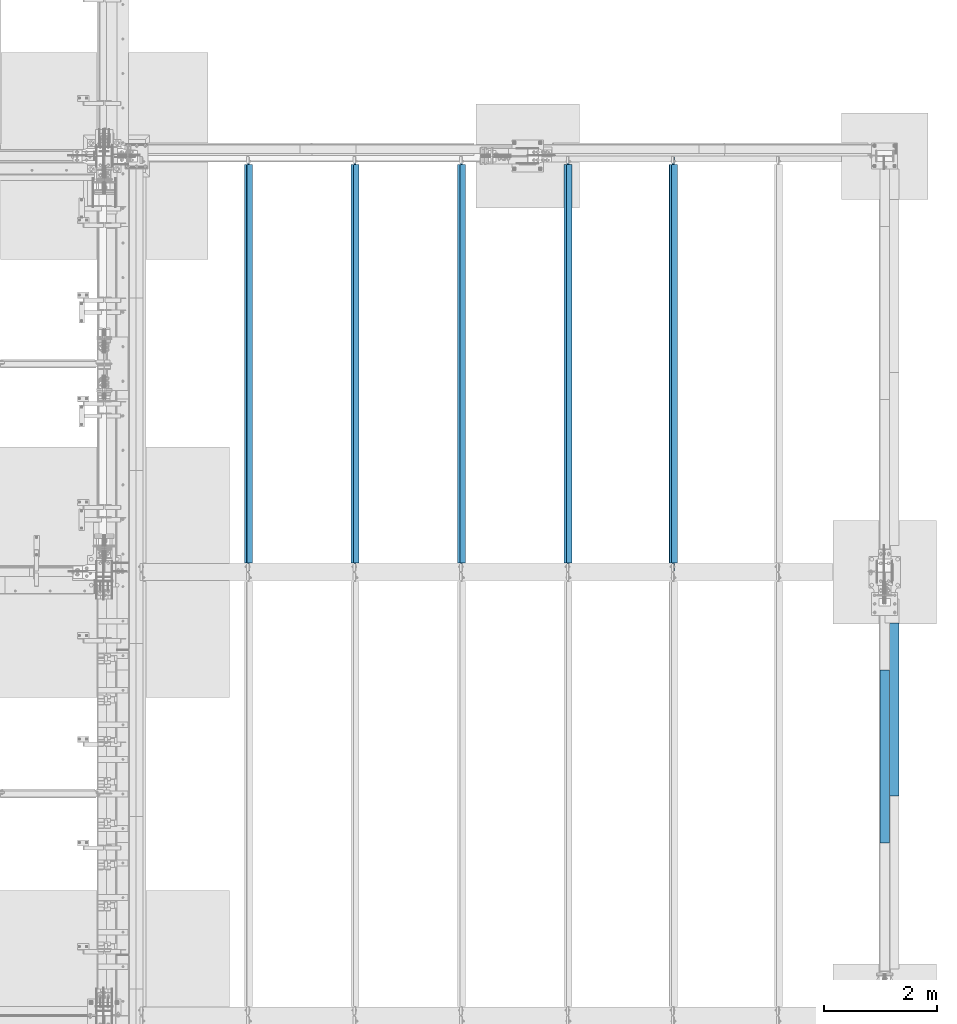
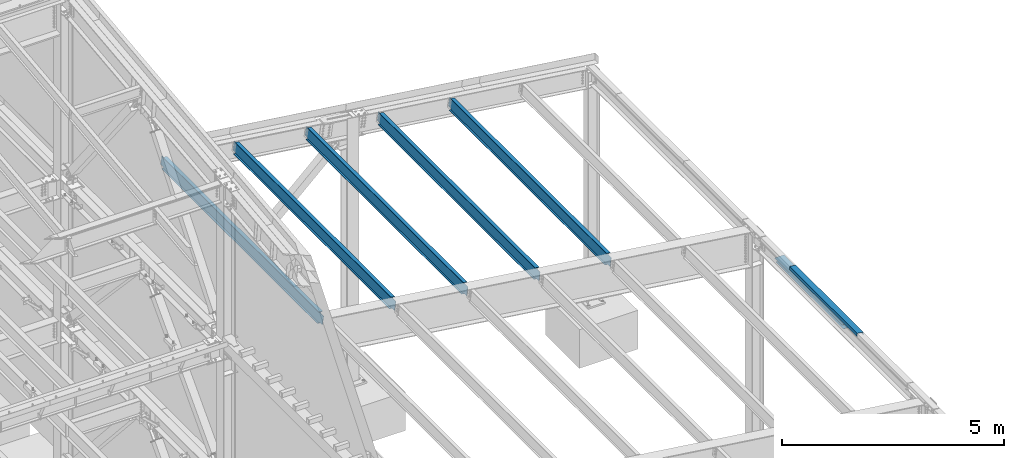
# One storey, part 751 of 1179: 7 beams, 6 elements without a shape of their own.
"""IFC2X3 building model written with IfcOpenShell, lengths in millimetres."""

from ifc_helpers import new_model, si_unit, frame, origin_with_axes, place, context, subcontext, project, spatial, faceted_brep, material, type_object, element, aggregate, save


model = new_model("IFC2X3")

# Units and contexts
model_context = context("Model", 3, precision=1e-05, world=origin_with_axes())
body_context = subcontext(model_context, "Body", "Model", "MODEL_VIEW")
ifc_project = project(units=[si_unit("LENGTHUNIT", "METRE", prefix="MILLI"), si_unit("AREAUNIT", "SQUARE_METRE"), si_unit("VOLUMEUNIT", "CUBIC_METRE"), si_unit("MASSUNIT", "GRAM", prefix="KILO"), si_unit("TIMEUNIT", "SECOND"), si_unit("PLANEANGLEUNIT", "RADIAN"), si_unit("SOLIDANGLEUNIT", "STERADIAN"), si_unit("THERMODYNAMICTEMPERATUREUNIT", "DEGREE_CELSIUS"), si_unit("LUMINOUSINTENSITYUNIT", "LUMEN")], contexts=[model_context])

# Site, building, storey
site_placement = place(None, origin_with_axes())
site = spatial("IfcSite", under=ifc_project, at=site_placement, CompositionType="ELEMENT")
building_placement = place(site_placement, origin_with_axes())
building = spatial("IfcBuilding", under=site, at=building_placement, Name="Undefined", CompositionType="ELEMENT")
storey_placement = place(building_placement, origin_with_axes())
storey = spatial("IfcBuildingStorey", under=building, at=storey_placement, Name="Undefined", CompositionType="ELEMENT", Elevation=0.0)

# Assembly, beams
assembly_1_placement = place(storey_placement, origin_with_axes())
assembly_1 = element("IfcElementAssembly", 1, at=assembly_1_placement, inside=storey, Name="BEAM", AssemblyPlace="NOTDEFINED", PredefinedType="RIGID_FRAME")
ifc_material_1 = material(Name="STEEL/A36")
beam_type_1 = type_object("IfcBeamType", PredefinedType="NOTDEFINED")
beam_1_placement = place(assembly_1_placement, frame((37996.8124994166, 23800.6191790178, 6096.00000000004), z_axis=(0.0, -1.0, 0.0), x_axis=(0.0, 0.0, 1.0)))
beam_1 = element("IfcBeam", 2, at=beam_1_placement, type_object=beam_type_1, material=ifc_material_1, Name="BENT_PLATE", context=body_context, shape_type="Brep", body=[
    faceted_brep([(-2.91038304567337e-11, -4.76250000000073, -1524.0), (-2.91038304567337e-11, -4.76250000000073, 1524.0), (2.91038304567337e-11, 4.76250000000073, 1524.0), (2.91038304567337e-11, 4.76250000000073, -1524.0), (92.8848876952779, 4.76250000074651, 1524.0), (92.8848876952779, 4.76250000074651, -1524.0), (81.9873102930469, -4.76249999933498, -1524.0), (81.9873102930469, -4.76249999933498, 1524.0), (70.5918350219381, -160.337506103519, 1524.0), (70.5918350219381, -160.337506103519, -1524.0), (62.266532833075, -150.812506103524, -1524.0), (62.266532833075, -150.812506103524, 1524.0), (-7.6397554948926e-11, -160.337506103519, 1524.0), (-7.6397554948926e-11, -160.337506103519, -1524.0), (8.54161044117063e-08, -150.812499999749, 1524.0), (8.54161044117063e-08, -150.812499999749, -1524.0)], [[[0, 1, 2, 3]], [[3, 2, 4, 5]], [[1, 0, 6, 7]], [[5, 4, 8, 9]], [[7, 6, 10, 11]], [[9, 8, 12, 13]], [[8, 4, 2, 1, 7, 11, 14, 12]], [[11, 10, 15, 14]], [[10, 6, 0, 3, 5, 9, 13, 15]], [[14, 15, 13, 12]]]),
])
beam_type_2 = type_object("IfcBeamType", PredefinedType="NOTDEFINED")
beam_2_placement = place(assembly_1_placement, frame((38113.49375, 24627.5611179414, 5764.21250000249), z_axis=(0.0, 1.0, 0.0), x_axis=(1.0, 0.0, 0.0)))
beam_2 = element("IfcBeam", 3, at=beam_2_placement, type_object=beam_type_2, material=ifc_material_1, Name="BENT_PLATE", context=body_context, shape_type="Brep", body=[
    faceted_brep([(0.0, -3.17499999999927, -1524.0), (6.00266503170133e-10, -3.17499999922438, 1524.00000000052), (6.00266503170133e-10, 3.17500000077416, 1524.00000000052), (0.0, 3.17499999999927, -1524.0), (215.900000000009, 3.17500000000018, 1524.0), (215.900000000009, 3.17500000000018, -1524.0), (209.550000000003, -3.17500000000018, -1524.0), (209.550000000003, -3.17500000000018, 1524.0), (215.900000000009, -123.825, 1524.0), (215.900000000009, -123.825, -1524.0), (209.550000000003, -117.474999999999, -1524.0), (209.550000000003, -117.474999999999, 1524.0), (-34.1312499999985, -123.825, 1524.0), (-34.1312499999985, -123.825, -1524.0), (-34.1312499999985, -117.474999999999, 1524.0), (-34.1312499999985, -117.474999999999, -1524.0)], [[[0, 1, 2, 3]], [[3, 2, 4, 5]], [[1, 0, 6, 7]], [[5, 4, 8, 9]], [[7, 6, 10, 11]], [[9, 8, 12, 13]], [[8, 4, 2, 1, 7, 11, 14, 12]], [[11, 10, 15, 14]], [[10, 6, 0, 3, 5, 9, 13, 15]], [[14, 15, 13, 12]]]),
])
aggregate(assembly_1, [beam_2, beam_1])

# Assembly, beam
assembly_2_placement = place(storey_placement, origin_with_axes())
assembly_2 = element("IfcElementAssembly", 4, at=assembly_2_placement, inside=storey, Name="BEAM", AssemblyPlace="NOTDEFINED", PredefinedType="RIGID_FRAME")
ifc_material_2 = material(Name="STEEL/A992")
beam_type_3 = type_object("IfcBeamType", Name="W12X22", PredefinedType="NOTDEFINED")
beam_3_placement = place(assembly_2_placement, frame((34345.3820076777, 27051.0, 6524.29881454697), z_axis=(0.133813223953133, 0.0, 0.991006569652931), x_axis=(0.0, 1.0, 0.0)))
beam_3 = element("IfcBeam", 5, at=beam_3_placement, type_object=beam_type_3, material=ifc_material_2, Name="BEAM", ObjectType="W12X22", context=body_context, shape_type="Brep", body=[
    faceted_brep([(7194.54999999999, -3.17499999982101, -144.462500000049), (7194.54999999999, -50.7999999998428, -144.462500000063), (7194.54999999999, -50.7999999998283, -155.575000000066), (7194.54999999999, 50.8000000001994, -155.575000000039), (7194.54999999999, 50.8000000001775, -144.462500000034), (7194.54999999999, 3.17500000017026, -144.462500000049), (7194.54999999999, 3.17500000015571, -136.524999807967), (7194.54999999999, -3.17499999984284, -136.524999807963), (7195.51672992258, 3.17500000016298, -131.664920289917), (7195.51672992258, -3.17499999984284, -131.664920289913), (7198.26974382306, 3.17500000015571, -127.54474382176), (7198.26974382306, -3.17499999985012, -127.544743821756), (7202.38992029121, 3.17500000014843, -124.791729921279), (7202.38992029121, -3.17499999985012, -124.791729921275), (7207.24999980926, 3.17500000014115, -123.824999998687), (7207.24999980926, -3.17499999985012, -123.824999998684), (7321.54999999999, -3.17499999985012, -123.82499999858), (7321.54999999999, 3.17500000014843, -123.824999998573), (161.925000000007, 3.17499999983556, 144.462500000051), (161.925000000007, 50.7999999998428, 144.462500000063), (7194.54999999999, 50.7999999998428, 144.462500000063), (7194.54999999999, 3.17499999983556, 144.462500000051), (161.925000000007, -3.17499999984284, -136.524999799629), (161.925000000007, 3.17500000016298, -136.524999799632), (161.925000000007, 3.17500000017026, -144.462500000049), (161.925000000007, 50.8000000001775, -144.462500000034), (161.925000000007, 50.8000000001994, -155.575000000039), (161.925000000007, -50.7999999998283, -155.575000000066), (161.925000000007, -50.7999999998428, -144.462500000063), (161.925000000007, -3.17499999982101, -144.462500000049), (160.958270077419, -3.17499999984284, -131.664920281577), (160.958270077419, 3.17500000015571, -131.664920281581), (158.205256176941, -3.17499999984284, -127.54474381342), (158.205256176941, 3.17500000014843, -127.544743813425), (154.085079708788, -3.17499999985012, -124.791729912939), (154.085079708788, 3.17500000015571, -124.791729912944), (149.225000190741, -3.17499999985012, -123.824999990349), (149.225000190741, 3.17500000014115, -123.824999990355), (20.6375000000044, -3.17499999985739, -123.824999990466), (20.6375000000044, 3.17500000014843, -123.824999990458), (20.6375000000044, -3.17500000014115, 117.475000009781), (20.6375000000044, 3.17499999986467, 117.475000009788), (149.225000190741, -3.17500000014115, 117.475000009897), (149.225000190741, 3.17499999986467, 117.475000009894), (154.085079708788, -3.17500000014115, 118.441729932485), (154.085079708788, 3.17499999986467, 118.441729932481), (158.205256176941, -3.17500000014843, 121.194743832966), (158.205256176941, 3.17499999985739, 121.194743832963), (160.958270077419, -3.17500000014843, 125.314920301123), (160.958270077419, 3.17499999985739, 125.31492030112), (161.925000000007, -3.17500000014843, 130.174999819174), (161.925000000007, 3.17499999985012, 130.17499981917), (161.925000000007, -50.8000000001994, 155.575000000041), (161.925000000007, 50.7999999998356, 155.575000000066), (161.925000000007, -3.17500000017026, 144.462500000049), (161.925000000007, -50.8000000001775, 144.462500000034), (7194.54999999999, -3.17500000017026, 144.462500000049), (7194.54999999999, -50.8000000001775, 144.462500000034), (7194.54999999999, -50.8000000001994, 155.575000000041), (7194.54999999999, 50.7999999998356, 155.575000000066), (7194.54999999999, -3.17500000014843, 130.174999810839), (7194.54999999999, 3.17499999984284, 130.174999810835), (7195.51672992258, -3.17500000014843, 125.314920292787), (7195.51672992258, 3.17499999985739, 125.314920292783), (7198.26974382306, -3.17500000014843, 121.19474382463), (7198.26974382306, 3.17499999985739, 121.194743824626), (7202.38992029121, -3.17500000014115, 118.441729924149), (7202.38992029121, 3.17499999985739, 118.441729924147), (7207.24999980926, -3.17500000014115, 117.475000001559), (7207.24999980926, 3.17499999985739, 117.475000001556), (7321.54999999999, -3.17500000014115, 117.475000001665), (7321.54999999999, 3.17499999985739, 117.475000001672)], [[[0, 1, 2, 3, 4, 5, 6, 7]], [[7, 6, 8, 9]], [[9, 8, 10, 11]], [[11, 10, 12, 13]], [[13, 12, 14, 15]], [[16, 15, 14, 17]], [[18, 19, 20, 21]], [[22, 23, 24, 25, 26, 27, 28, 29]], [[30, 31, 23, 22]], [[32, 33, 31, 30]], [[34, 35, 33, 32]], [[36, 37, 35, 34]], [[38, 39, 37, 36]], [[40, 41, 39, 38]], [[42, 43, 41, 40]], [[44, 45, 43, 42]], [[46, 47, 45, 44]], [[48, 49, 47, 46]], [[50, 51, 49, 48]], [[52, 53, 19, 18, 51, 50, 54, 55]], [[55, 54, 56, 57]], [[52, 55, 57, 58]], [[53, 52, 58, 59]], [[19, 53, 59, 20]], [[58, 57, 56, 60, 61, 21, 20, 59]], [[62, 63, 61, 60]], [[64, 65, 63, 62]], [[66, 67, 65, 64]], [[68, 69, 67, 66]], [[70, 71, 69, 68]], [[71, 70, 16, 17]], [[12, 10, 8, 6, 5, 24, 23, 31, 33, 35, 37, 39, 41, 43, 45, 47, 49, 51, 18, 21, 61, 63, 65, 67, 69, 71, 17, 14]], [[25, 24, 5, 4]], [[26, 25, 4, 3]], [[27, 26, 3, 2]], [[28, 27, 2, 1]], [[29, 28, 1, 0]], [[70, 68, 66, 64, 62, 60, 56, 54, 50, 48, 46, 44, 42, 40, 38, 36, 34, 32, 30, 22, 29, 0, 7, 9, 11, 13, 15, 16]]]),
])
aggregate(assembly_2, [beam_3])

assembly_3_placement = place(storey_placement, origin_with_axes())
assembly_3 = element("IfcElementAssembly", 6, at=assembly_3_placement, inside=storey, Name="BEAM", AssemblyPlace="NOTDEFINED", PredefinedType="RIGID_FRAME")
beam_4_placement = place(assembly_3_placement, frame((32491.1820076773, 27051.0, 6774.66696290236), z_axis=(0.133813223953133, 0.0, 0.991006569652931), x_axis=(0.0, 1.0, 0.0)))
beam_4 = element("IfcBeam", 7, at=beam_4_placement, type_object=beam_type_3, material=ifc_material_2, Name="BEAM", ObjectType="W12X22", context=body_context, shape_type="Brep", body=[
    faceted_brep([(7194.54999999999, -3.17499999982101, -144.462500000049), (7194.54999999999, -50.7999999998428, -144.462500000063), (7194.54999999999, -50.7999999998283, -155.575000000066), (7194.54999999999, 50.8000000001994, -155.575000000039), (7194.54999999999, 50.8000000001775, -144.462500000034), (7194.54999999999, 3.17500000017026, -144.462500000049), (7194.54999999999, 3.17500000015571, -136.524999807967), (7194.54999999999, -3.17499999984284, -136.524999807963), (7195.51672992258, 3.17500000016298, -131.664920289917), (7195.51672992258, -3.17499999984284, -131.664920289913), (7198.26974382306, 3.17500000015571, -127.54474382176), (7198.26974382306, -3.17499999985012, -127.544743821756), (7202.38992029121, 3.17500000014843, -124.791729921279), (7202.38992029121, -3.17499999985012, -124.791729921275), (7207.24999980926, 3.17500000014115, -123.824999998687), (7207.24999980926, -3.17499999985012, -123.824999998684), (7321.54999999999, -3.17499999985012, -123.82499999858), (7321.54999999999, 3.17500000014843, -123.824999998573), (161.925000000007, 3.17499999983556, 144.462500000051), (161.925000000007, 50.7999999998428, 144.462500000063), (7194.54999999999, 50.7999999998428, 144.462500000063), (7194.54999999999, 3.17499999983556, 144.462500000051), (161.925000000007, -3.17499999984284, -136.524999799629), (161.925000000007, 3.17500000016298, -136.524999799632), (161.925000000007, 3.17500000017026, -144.462500000049), (161.925000000007, 50.8000000001775, -144.462500000034), (161.925000000007, 50.8000000001994, -155.575000000039), (161.925000000007, -50.7999999998283, -155.575000000066), (161.925000000007, -50.7999999998428, -144.462500000063), (161.925000000007, -3.17499999982101, -144.462500000049), (160.958270077419, -3.17499999984284, -131.664920281577), (160.958270077419, 3.17500000015571, -131.664920281581), (158.205256176941, -3.17499999984284, -127.54474381342), (158.205256176941, 3.17500000014843, -127.544743813425), (154.085079708788, -3.17499999985012, -124.791729912939), (154.085079708788, 3.17500000015571, -124.791729912944), (149.225000190741, -3.17499999985012, -123.824999990349), (149.225000190741, 3.17500000014115, -123.824999990355), (20.6375000000044, -3.17499999985739, -123.824999990466), (20.6375000000044, 3.17500000014843, -123.824999990458), (20.6375000000044, -3.17500000014115, 117.475000009781), (20.6375000000044, 3.17499999986467, 117.475000009788), (149.225000190741, -3.17500000014115, 117.475000009897), (149.225000190741, 3.17499999986467, 117.475000009894), (154.085079708788, -3.17500000014115, 118.441729932485), (154.085079708788, 3.17499999986467, 118.441729932481), (158.205256176941, -3.17500000014843, 121.194743832966), (158.205256176941, 3.17499999985739, 121.194743832963), (160.958270077419, -3.17500000014843, 125.314920301123), (160.958270077419, 3.17499999985739, 125.31492030112), (161.925000000007, -3.17500000014843, 130.174999819174), (161.925000000007, 3.17499999985012, 130.17499981917), (161.925000000007, -50.8000000001994, 155.575000000041), (161.925000000007, 50.7999999998356, 155.575000000066), (161.925000000007, -3.17500000017026, 144.462500000049), (161.925000000007, -50.8000000001775, 144.462500000034), (7194.54999999999, -3.17500000017026, 144.462500000049), (7194.54999999999, -50.8000000001775, 144.462500000034), (7194.54999999999, -50.8000000001994, 155.575000000041), (7194.54999999999, 50.7999999998356, 155.575000000066), (7194.54999999999, -3.17500000014843, 130.174999810839), (7194.54999999999, 3.17499999984284, 130.174999810835), (7195.51672992258, -3.17500000014843, 125.314920292787), (7195.51672992258, 3.17499999985739, 125.314920292783), (7198.26974382306, -3.17500000014843, 121.19474382463), (7198.26974382306, 3.17499999985739, 121.194743824626), (7202.38992029121, -3.17500000014115, 118.441729924149), (7202.38992029121, 3.17499999985739, 118.441729924147), (7207.24999980926, -3.17500000014115, 117.475000001559), (7207.24999980926, 3.17499999985739, 117.475000001556), (7321.54999999999, -3.17500000014115, 117.475000001665), (7321.54999999999, 3.17499999985739, 117.475000001672)], [[[0, 1, 2, 3, 4, 5, 6, 7]], [[7, 6, 8, 9]], [[9, 8, 10, 11]], [[11, 10, 12, 13]], [[13, 12, 14, 15]], [[16, 15, 14, 17]], [[18, 19, 20, 21]], [[22, 23, 24, 25, 26, 27, 28, 29]], [[30, 31, 23, 22]], [[32, 33, 31, 30]], [[34, 35, 33, 32]], [[36, 37, 35, 34]], [[38, 39, 37, 36]], [[40, 41, 39, 38]], [[42, 43, 41, 40]], [[44, 45, 43, 42]], [[46, 47, 45, 44]], [[48, 49, 47, 46]], [[50, 51, 49, 48]], [[52, 53, 19, 18, 51, 50, 54, 55]], [[55, 54, 56, 57]], [[52, 55, 57, 58]], [[53, 52, 58, 59]], [[19, 53, 59, 20]], [[58, 57, 56, 60, 61, 21, 20, 59]], [[62, 63, 61, 60]], [[64, 65, 63, 62]], [[66, 67, 65, 64]], [[68, 69, 67, 66]], [[70, 71, 69, 68]], [[71, 70, 16, 17]], [[12, 10, 8, 6, 5, 24, 23, 31, 33, 35, 37, 39, 41, 43, 45, 47, 49, 51, 18, 21, 61, 63, 65, 67, 69, 71, 17, 14]], [[25, 24, 5, 4]], [[26, 25, 4, 3]], [[27, 26, 3, 2]], [[28, 27, 2, 1]], [[29, 28, 1, 0]], [[70, 68, 66, 64, 62, 60, 56, 54, 50, 48, 46, 44, 42, 40, 38, 36, 34, 32, 30, 22, 29, 0, 7, 9, 11, 13, 15, 16]]]),
])
aggregate(assembly_3, [beam_4])

assembly_4_placement = place(storey_placement, origin_with_axes())
assembly_4 = element("IfcElementAssembly", 8, at=assembly_4_placement, inside=storey, Name="BEAM", AssemblyPlace="NOTDEFINED", PredefinedType="RIGID_FRAME")
beam_5_placement = place(assembly_4_placement, frame((30611.5820076832, 27051.0, 7028.46481116704), z_axis=(0.133813223953133, 0.0, 0.991006569652931), x_axis=(0.0, 1.0, 0.0)))
beam_5 = element("IfcBeam", 9, at=beam_5_placement, type_object=beam_type_3, material=ifc_material_2, Name="BEAM", ObjectType="W12X22", context=body_context, shape_type="Brep", body=[
    faceted_brep([(7192.96250000001, -3.1749999998392, -144.462500000049), (7192.96250000001, -50.7999999998501, -144.46250000006), (7192.96250000001, -50.7999999998356, -155.575000000066), (7192.96250000001, 50.8000000001848, -155.575000000037), (7192.96250000001, 50.8000000001775, -144.462500000034), (7192.96250000001, 3.17500000016298, -144.462500000047), (7192.96250000001, 3.17500000015571, -136.524999802685), (7192.96250000001, -3.17499999984648, -136.524999802681), (7193.9292299226, 3.17500000014843, -131.664920284635), (7193.9292299226, -3.17499999985375, -131.664920284631), (7196.68224382308, 3.17500000014115, -127.544743816477), (7196.68224382308, -3.17499999985739, -127.544743816472), (7200.80242029123, 3.17500000014115, -124.791729915994), (7200.80242029123, -3.17499999986103, -124.791729915993), (7205.66249980928, 3.17500000014115, -123.824999993407), (7205.66249980928, -3.17499999986103, -123.824999993401), (7319.96250000001, -3.17499999986103, -123.824999993298), (7319.96250000001, 3.17500000013752, -123.82499999329), (161.925000000007, 3.17499999983556, 144.462500000051), (161.925000000007, 50.7999999998428, 144.462500000063), (7192.96250000001, 50.7999999998356, 144.462500000063), (7192.96250000001, 3.17499999982465, 144.462500000052), (161.925000000007, -3.17499999984284, -136.524999799629), (161.925000000007, 3.17500000016298, -136.524999799632), (161.925000000007, 3.17500000017026, -144.462500000049), (161.925000000007, 50.8000000001775, -144.462500000034), (161.925000000007, 50.8000000001994, -155.575000000039), (161.925000000007, -50.7999999998283, -155.575000000066), (161.925000000007, -50.7999999998428, -144.462500000063), (161.925000000007, -3.17499999982101, -144.462500000049), (160.958270077419, -3.17499999984284, -131.664920281577), (160.958270077419, 3.17500000015571, -131.664920281581), (158.205256176941, -3.17499999984284, -127.54474381342), (158.205256176941, 3.17500000014843, -127.544743813425), (154.085079708788, -3.17499999985012, -124.791729912939), (154.085079708788, 3.17500000015571, -124.791729912944), (149.225000190741, -3.17499999985012, -123.824999990349), (149.225000190741, 3.17500000014115, -123.824999990355), (20.6375000000044, -3.17499999985739, -123.824999990466), (20.6375000000044, 3.17500000014843, -123.824999990458), (20.6375000000044, -3.17500000014115, 117.475000009781), (20.6375000000044, 3.17499999986467, 117.475000009788), (149.225000190741, -3.17500000014115, 117.475000009897), (149.225000190741, 3.17499999986467, 117.475000009894), (154.085079708788, -3.17500000014115, 118.441729932485), (154.085079708788, 3.17499999986467, 118.441729932481), (158.205256176941, -3.17500000014843, 121.194743832966), (158.205256176941, 3.17499999985739, 121.194743832963), (160.958270077419, -3.17500000014843, 125.314920301123), (160.958270077419, 3.17499999985739, 125.31492030112), (161.925000000007, -3.17500000014843, 130.174999819174), (161.925000000007, 3.17499999985012, 130.17499981917), (161.925000000007, -50.8000000001994, 155.575000000041), (161.925000000007, 50.7999999998356, 155.575000000066), (161.925000000007, -3.17500000017026, 144.462500000049), (161.925000000007, -50.8000000001775, 144.462500000034), (7192.96250000001, -3.17500000017753, 144.462500000049), (7192.96250000001, -50.8000000001921, 144.462500000038), (7192.96250000001, -50.8000000001994, 155.575000000041), (7192.96250000001, 50.799999999821, 155.57500000007), (7192.96250000001, -3.17500000016298, 130.174999815979), (7192.96250000001, 3.1749999998392, 130.174999815976), (7193.9292299226, -3.17500000015207, 125.314920297929), (7193.9292299226, 3.17499999984648, 125.314920297926), (7196.68224382308, -3.17500000014843, 121.194743829772), (7196.68224382308, 3.17499999985375, 121.194743829768), (7200.80242029123, -3.17500000014479, 118.441729929291), (7200.80242029123, 3.17499999985375, 118.441729929287), (7205.66249980928, -3.17500000014843, 117.475000006702), (7205.66249980928, 3.17499999985375, 117.4750000067), (7319.96250000001, -3.17500000014843, 117.475000006809), (7319.96250000001, 3.17499999985375, 117.475000006812)], [[[0, 1, 2, 3, 4, 5, 6, 7]], [[7, 6, 8, 9]], [[9, 8, 10, 11]], [[11, 10, 12, 13]], [[13, 12, 14, 15]], [[16, 15, 14, 17]], [[18, 19, 20, 21]], [[22, 23, 24, 25, 26, 27, 28, 29]], [[30, 31, 23, 22]], [[32, 33, 31, 30]], [[34, 35, 33, 32]], [[36, 37, 35, 34]], [[38, 39, 37, 36]], [[40, 41, 39, 38]], [[42, 43, 41, 40]], [[44, 45, 43, 42]], [[46, 47, 45, 44]], [[48, 49, 47, 46]], [[50, 51, 49, 48]], [[52, 53, 19, 18, 51, 50, 54, 55]], [[55, 54, 56, 57]], [[52, 55, 57, 58]], [[53, 52, 58, 59]], [[19, 53, 59, 20]], [[58, 57, 56, 60, 61, 21, 20, 59]], [[62, 63, 61, 60]], [[64, 65, 63, 62]], [[66, 67, 65, 64]], [[68, 69, 67, 66]], [[70, 71, 69, 68]], [[71, 70, 16, 17]], [[12, 10, 8, 6, 5, 24, 23, 31, 33, 35, 37, 39, 41, 43, 45, 47, 49, 51, 18, 21, 61, 63, 65, 67, 69, 71, 17, 14]], [[25, 24, 5, 4]], [[26, 25, 4, 3]], [[27, 26, 3, 2]], [[28, 27, 2, 1]], [[29, 28, 1, 0]], [[70, 68, 66, 64, 62, 60, 56, 54, 50, 48, 46, 44, 42, 40, 38, 36, 34, 32, 30, 22, 29, 0, 7, 9, 11, 13, 15, 16]]]),
])
aggregate(assembly_4, [beam_5])

assembly_5_placement = place(storey_placement, origin_with_axes())
assembly_5 = element("IfcElementAssembly", 10, at=assembly_5_placement, inside=storey, Name="BEAM", AssemblyPlace="NOTDEFINED", PredefinedType="RIGID_FRAME")
beam_6_placement = place(assembly_5_placement, frame((28731.9820076832, 27051.0, 7282.26266018504), z_axis=(0.133813223953133, 0.0, 0.991006569652931), x_axis=(0.0, 1.0, 0.0)))
beam_6 = element("IfcBeam", 11, at=beam_6_placement, type_object=beam_type_3, material=ifc_material_2, Name="BEAM", ObjectType="W12X22", context=body_context, shape_type="Brep", body=[
    faceted_brep([(7192.96250000001, -3.1749999998392, -144.462500000049), (7192.96250000001, -50.7999999998501, -144.46250000006), (7192.96250000001, -50.7999999998356, -155.575000000066), (7192.96250000001, 50.8000000001848, -155.575000000037), (7192.96250000001, 50.8000000001775, -144.462500000034), (7192.96250000001, 3.17500000016298, -144.462500000047), (7192.96250000001, 3.17500000015571, -136.524999802685), (7192.96250000001, -3.17499999984648, -136.524999802681), (7193.9292299226, 3.17500000014843, -131.664920284635), (7193.9292299226, -3.17499999985375, -131.664920284631), (7196.68224382308, 3.17500000014115, -127.544743816477), (7196.68224382308, -3.17499999985739, -127.544743816472), (7200.80242029123, 3.17500000014115, -124.791729915994), (7200.80242029123, -3.17499999986103, -124.791729915993), (7205.66249980928, 3.17500000014115, -123.824999993407), (7205.66249980928, -3.17499999986103, -123.824999993401), (7319.96250000001, -3.17499999986103, -123.824999993298), (7319.96250000001, 3.17500000013752, -123.82499999329), (161.925000000007, 3.17499999983556, 144.462500000051), (161.925000000007, 50.7999999998428, 144.462500000063), (7192.96250000001, 50.7999999998356, 144.462500000063), (7192.96250000001, 3.17499999982465, 144.462500000052), (161.925000000007, -3.17499999984284, -136.524999799629), (161.925000000007, 3.17500000016298, -136.524999799632), (161.925000000007, 3.17500000017026, -144.462500000049), (161.925000000007, 50.8000000001775, -144.462500000034), (161.925000000007, 50.8000000001994, -155.575000000039), (161.925000000007, -50.7999999998283, -155.575000000066), (161.925000000007, -50.7999999998428, -144.462500000063), (161.925000000007, -3.17499999982101, -144.462500000049), (160.958270077419, -3.17499999984284, -131.664920281577), (160.958270077419, 3.17500000015571, -131.664920281581), (158.205256176941, -3.17499999984284, -127.54474381342), (158.205256176941, 3.17500000014843, -127.544743813425), (154.085079708788, -3.17499999985012, -124.791729912939), (154.085079708788, 3.17500000015571, -124.791729912944), (149.225000190741, -3.17499999985012, -123.824999990349), (149.225000190741, 3.17500000014115, -123.824999990355), (20.6375000000044, -3.17499999985739, -123.824999990466), (20.6375000000044, 3.17500000014843, -123.824999990458), (20.6375000000044, -3.17500000014115, 117.475000009781), (20.6375000000044, 3.17499999986467, 117.475000009788), (149.225000190741, -3.17500000014115, 117.475000009897), (149.225000190741, 3.17499999986467, 117.475000009894), (154.085079708788, -3.17500000014115, 118.441729932485), (154.085079708788, 3.17499999986467, 118.441729932481), (158.205256176941, -3.17500000014843, 121.194743832966), (158.205256176941, 3.17499999985739, 121.194743832963), (160.958270077419, -3.17500000014843, 125.314920301123), (160.958270077419, 3.17499999985739, 125.31492030112), (161.925000000007, -3.17500000014843, 130.174999819174), (161.925000000007, 3.17499999985012, 130.17499981917), (161.925000000007, -50.8000000001994, 155.575000000041), (161.925000000007, 50.7999999998356, 155.575000000066), (161.925000000007, -3.17500000017026, 144.462500000049), (161.925000000007, -50.8000000001775, 144.462500000034), (7192.96250000001, -3.17500000017753, 144.462500000049), (7192.96250000001, -50.8000000001921, 144.462500000038), (7192.96250000001, -50.8000000001994, 155.575000000041), (7192.96250000001, 50.799999999821, 155.57500000007), (7192.96250000001, -3.17500000016298, 130.174999815979), (7192.96250000001, 3.1749999998392, 130.174999815976), (7193.9292299226, -3.17500000015207, 125.314920297929), (7193.9292299226, 3.17499999984648, 125.314920297926), (7196.68224382308, -3.17500000014843, 121.194743829772), (7196.68224382308, 3.17499999985375, 121.194743829768), (7200.80242029123, -3.17500000014479, 118.441729929291), (7200.80242029123, 3.17499999985375, 118.441729929287), (7205.66249980928, -3.17500000014843, 117.475000006702), (7205.66249980928, 3.17499999985375, 117.4750000067), (7319.96250000001, -3.17500000014843, 117.475000006809), (7319.96250000001, 3.17499999985375, 117.475000006812)], [[[0, 1, 2, 3, 4, 5, 6, 7]], [[7, 6, 8, 9]], [[9, 8, 10, 11]], [[11, 10, 12, 13]], [[13, 12, 14, 15]], [[16, 15, 14, 17]], [[18, 19, 20, 21]], [[22, 23, 24, 25, 26, 27, 28, 29]], [[30, 31, 23, 22]], [[32, 33, 31, 30]], [[34, 35, 33, 32]], [[36, 37, 35, 34]], [[38, 39, 37, 36]], [[40, 41, 39, 38]], [[42, 43, 41, 40]], [[44, 45, 43, 42]], [[46, 47, 45, 44]], [[48, 49, 47, 46]], [[50, 51, 49, 48]], [[52, 53, 19, 18, 51, 50, 54, 55]], [[55, 54, 56, 57]], [[52, 55, 57, 58]], [[53, 52, 58, 59]], [[19, 53, 59, 20]], [[58, 57, 56, 60, 61, 21, 20, 59]], [[62, 63, 61, 60]], [[64, 65, 63, 62]], [[66, 67, 65, 64]], [[68, 69, 67, 66]], [[70, 71, 69, 68]], [[71, 70, 16, 17]], [[12, 10, 8, 6, 5, 24, 23, 31, 33, 35, 37, 39, 41, 43, 45, 47, 49, 51, 18, 21, 61, 63, 65, 67, 69, 71, 17, 14]], [[25, 24, 5, 4]], [[26, 25, 4, 3]], [[27, 26, 3, 2]], [[28, 27, 2, 1]], [[29, 28, 1, 0]], [[70, 68, 66, 64, 62, 60, 56, 54, 50, 48, 46, 44, 42, 40, 38, 36, 34, 32, 30, 22, 29, 0, 7, 9, 11, 13, 15, 16]]]),
])
aggregate(assembly_5, [beam_6])

assembly_6_placement = place(storey_placement, origin_with_axes())
assembly_6 = element("IfcElementAssembly", 12, at=assembly_6_placement, inside=storey, Name="BEAM", AssemblyPlace="NOTDEFINED", PredefinedType="RIGID_FRAME")
beam_7_placement = place(assembly_6_placement, frame((26852.3820076832, 27051.0, 7536.06050920301), z_axis=(0.133813223953133, 0.0, 0.991006569652931), x_axis=(0.0, 1.0, 0.0)))
beam_7 = element("IfcBeam", 13, at=beam_7_placement, type_object=beam_type_3, material=ifc_material_2, Name="BEAM", ObjectType="W12X22", context=body_context, shape_type="Brep", body=[
    faceted_brep([(7192.96250000001, -3.1749999998392, -144.462500000049), (7192.96250000001, -50.7999999998501, -144.46250000006), (7192.96250000001, -50.7999999998356, -155.575000000066), (7192.96250000001, 50.8000000001848, -155.575000000037), (7192.96250000001, 50.8000000001775, -144.462500000034), (7192.96250000001, 3.17500000016298, -144.462500000047), (7192.96250000001, 3.17500000015571, -136.524999802685), (7192.96250000001, -3.17499999984648, -136.524999802681), (7193.9292299226, 3.17500000014843, -131.664920284635), (7193.9292299226, -3.17499999985375, -131.664920284631), (7196.68224382308, 3.17500000014115, -127.544743816477), (7196.68224382308, -3.17499999985739, -127.544743816472), (7200.80242029123, 3.17500000014115, -124.791729915994), (7200.80242029123, -3.17499999986103, -124.791729915993), (7205.66249980928, 3.17500000014115, -123.824999993407), (7205.66249980928, -3.17499999986103, -123.824999993401), (7319.96250000001, -3.17499999986103, -123.824999993298), (7319.96250000001, 3.17500000013752, -123.82499999329), (161.925000000007, 3.17499999983556, 144.462500000051), (161.925000000007, 50.7999999998428, 144.462500000063), (7192.96250000001, 50.7999999998356, 144.462500000063), (7192.96250000001, 3.17499999982465, 144.462500000052), (161.925000000007, -3.17499999984284, -136.524999799629), (161.925000000007, 3.17500000016298, -136.524999799632), (161.925000000007, 3.17500000017026, -144.462500000049), (161.925000000007, 50.8000000001775, -144.462500000034), (161.925000000007, 50.8000000001994, -155.575000000039), (161.925000000007, -50.7999999998283, -155.575000000066), (161.925000000007, -50.7999999998428, -144.462500000063), (161.925000000007, -3.17499999982101, -144.462500000049), (160.958270077419, -3.17499999984284, -131.664920281577), (160.958270077419, 3.17500000015571, -131.664920281581), (158.205256176941, -3.17499999984284, -127.54474381342), (158.205256176941, 3.17500000014843, -127.544743813425), (154.085079708788, -3.17499999985012, -124.791729912939), (154.085079708788, 3.17500000015571, -124.791729912944), (149.225000190741, -3.17499999985012, -123.824999990349), (149.225000190741, 3.17500000014115, -123.824999990355), (20.6375000000044, -3.17499999985739, -123.824999990466), (20.6375000000044, 3.17500000014843, -123.824999990458), (20.6375000000044, -3.17500000014115, 117.475000009781), (20.6375000000044, 3.17499999986467, 117.475000009788), (149.225000190741, -3.17500000014115, 117.475000009897), (149.225000190741, 3.17499999986467, 117.475000009894), (154.085079708788, -3.17500000014115, 118.441729932485), (154.085079708788, 3.17499999986467, 118.441729932481), (158.205256176941, -3.17500000014843, 121.194743832966), (158.205256176941, 3.17499999985739, 121.194743832963), (160.958270077419, -3.17500000014843, 125.314920301123), (160.958270077419, 3.17499999985739, 125.31492030112), (161.925000000007, -3.17500000014843, 130.174999819174), (161.925000000007, 3.17499999985012, 130.17499981917), (161.925000000007, -50.8000000001994, 155.575000000041), (161.925000000007, 50.7999999998356, 155.575000000066), (161.925000000007, -3.17500000017026, 144.462500000049), (161.925000000007, -50.8000000001775, 144.462500000034), (7192.96250000001, -3.17500000017753, 144.462500000049), (7192.96250000001, -50.8000000001921, 144.462500000038), (7192.96250000001, -50.8000000001994, 155.575000000041), (7192.96250000001, 50.799999999821, 155.57500000007), (7192.96250000001, -3.17500000016298, 130.174999815979), (7192.96250000001, 3.1749999998392, 130.174999815976), (7193.9292299226, -3.17500000015207, 125.314920297929), (7193.9292299226, 3.17499999984648, 125.314920297926), (7196.68224382308, -3.17500000014843, 121.194743829772), (7196.68224382308, 3.17499999985375, 121.194743829768), (7200.80242029123, -3.17500000014479, 118.441729929291), (7200.80242029123, 3.17499999985375, 118.441729929287), (7205.66249980928, -3.17500000014843, 117.475000006702), (7205.66249980928, 3.17499999985375, 117.4750000067), (7319.96250000001, -3.17500000014843, 117.475000006809), (7319.96250000001, 3.17499999985375, 117.475000006812)], [[[0, 1, 2, 3, 4, 5, 6, 7]], [[7, 6, 8, 9]], [[9, 8, 10, 11]], [[11, 10, 12, 13]], [[13, 12, 14, 15]], [[16, 15, 14, 17]], [[18, 19, 20, 21]], [[22, 23, 24, 25, 26, 27, 28, 29]], [[30, 31, 23, 22]], [[32, 33, 31, 30]], [[34, 35, 33, 32]], [[36, 37, 35, 34]], [[38, 39, 37, 36]], [[40, 41, 39, 38]], [[42, 43, 41, 40]], [[44, 45, 43, 42]], [[46, 47, 45, 44]], [[48, 49, 47, 46]], [[50, 51, 49, 48]], [[52, 53, 19, 18, 51, 50, 54, 55]], [[55, 54, 56, 57]], [[52, 55, 57, 58]], [[53, 52, 58, 59]], [[19, 53, 59, 20]], [[58, 57, 56, 60, 61, 21, 20, 59]], [[62, 63, 61, 60]], [[64, 65, 63, 62]], [[66, 67, 65, 64]], [[68, 69, 67, 66]], [[70, 71, 69, 68]], [[71, 70, 16, 17]], [[12, 10, 8, 6, 5, 24, 23, 31, 33, 35, 37, 39, 41, 43, 45, 47, 49, 51, 18, 21, 61, 63, 65, 67, 69, 71, 17, 14]], [[25, 24, 5, 4]], [[26, 25, 4, 3]], [[27, 26, 3, 2]], [[28, 27, 2, 1]], [[29, 28, 1, 0]], [[70, 68, 66, 64, 62, 60, 56, 54, 50, 48, 46, 44, 42, 40, 38, 36, 34, 32, 30, 22, 29, 0, 7, 9, 11, 13, 15, 16]]]),
])
aggregate(assembly_6, [beam_7])

save(model, "model.ifc")
